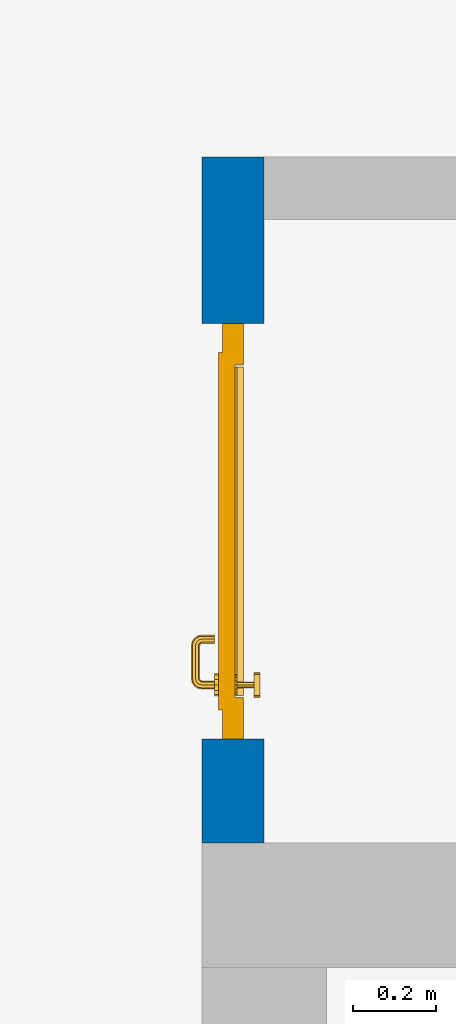
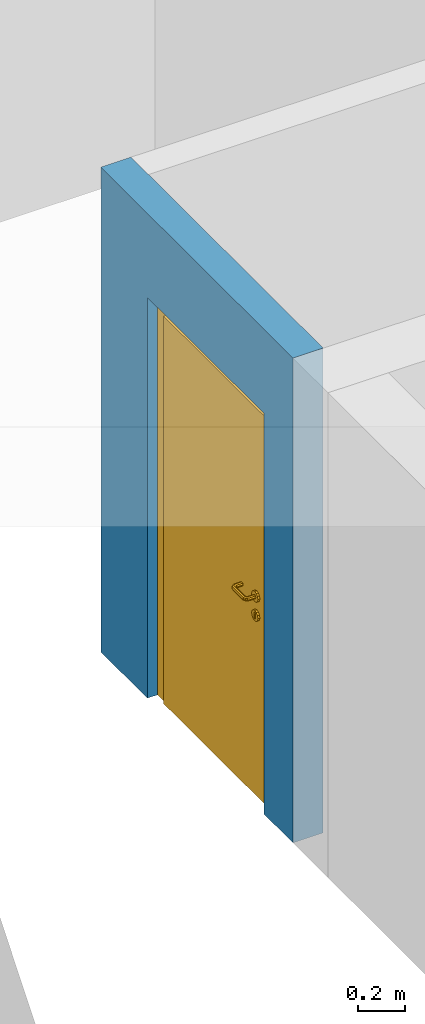
# One storey, part 15 of 48: 1 door, 1 wall, 1 opening.
"""IFC4 building model written with IfcOpenShell, lengths in metres."""

from ifc_helpers import new_model, entity, si_unit, converted_unit, derived_unit, direction, frame, origin_with_axes, place, context, subcontext, project, spatial, polygons, source, transform, mapped, material, type_object, element, fill, save


model = new_model("IFC4")

# Units and contexts
model_context = context("Model", 3, precision=1e-05, world=origin_with_axes(), true_north=direction((0.0, 1.0)))
body_context = subcontext(model_context, "Body", "Model", "MODEL_VIEW")
ifc_project = project(units=[si_unit("LENGTHUNIT", "METRE"), si_unit("AREAUNIT", "SQUARE_METRE"), si_unit("VOLUMEUNIT", "CUBIC_METRE"), converted_unit("PLANEANGLEUNIT", "DEGREE", entity("IfcPlaneAngleMeasure", 0.0174532925199), si_unit("PLANEANGLEUNIT", "RADIAN"), dimensions=[0, 0, 0, 0, 0, 0, 0]), converted_unit("TIMEUNIT", "Year", entity("IfcTimeMeasure", 31556926.0), si_unit("TIMEUNIT", "SECOND"), dimensions=[0, 0, 1, 0, 0, 0, 0]), si_unit("MASSUNIT", "GRAM", prefix="KILO"), si_unit("THERMODYNAMICTEMPERATUREUNIT", "DEGREE_CELSIUS"), si_unit("LUMINOUSINTENSITYUNIT", "LUMEN"), si_unit("ENERGYUNIT", "JOULE", prefix="MEGA"), derived_unit("THERMALCONDUCTANCEUNIT", [(si_unit("POWERUNIT", "WATT"), 1), (si_unit("LENGTHUNIT", "METRE"), -1), (si_unit("THERMODYNAMICTEMPERATUREUNIT", "KELVIN"), -1)]), derived_unit("SPECIFICHEATCAPACITYUNIT", [(si_unit("ENERGYUNIT", "JOULE"), 1), (si_unit("MASSUNIT", "GRAM", prefix="KILO"), -1), (si_unit("THERMODYNAMICTEMPERATUREUNIT", "KELVIN"), -1)]), derived_unit("MASSDENSITYUNIT", [(si_unit("MASSUNIT", "GRAM", prefix="KILO"), 1), (si_unit("VOLUMEUNIT", "CUBIC_METRE"), -1)])], contexts=[model_context])

# Site, building, storey
site_placement = place(None, origin_with_axes())
site = spatial("IfcSite", under=ifc_project, at=site_placement, CompositionType="ELEMENT")
building_placement = place(site_placement, origin_with_axes())
building = spatial("IfcBuilding", under=site, at=building_placement, CompositionType="ELEMENT")
storey_placement = place(building_placement, frame((0.0, 0.0, 3.4), z_axis=(0.0, 0.0, 1.0), x_axis=(1.0, 0.0, 0.0)))
storey = spatial("IfcBuildingStorey", under=building, at=storey_placement, Name="1. Geschoss", CompositionType="ELEMENT", Elevation=3.4)

# Wall, opening, door
ifc_material = material()
wall_type = type_object("IfcWallType", Name="150", PredefinedType="NOTDEFINED")
wall_placement = place(storey_placement, frame((-2.7421993804, 3.67118776896, 0.0), z_axis=(0.0, 0.0, 1.0), x_axis=(0.0, 1.0, 0.0)))
wall = element("IfcWall", 1, at=wall_placement, inside=storey, type_object=wall_type, material=ifc_material, Name="Wand-002", PredefinedType="NOTDEFINED", context=body_context, shape_type="Tessellation", body=[
    polygons([(0.55, -0.1, 2.1), (1.55, -0.1, 2.1), (1.55, -0.15, 2.1), (0.55, -0.15, 2.1), (0.55, 0.0, 2.1), (1.55, 0.0, 2.1), (1.55, -0.1, 0.0), (1.55, -0.15, 0.0), (1.95, -0.15, 2.54), (0.3, -0.15, 2.54), (0.3, -0.15, 0.0), (0.55, -0.15, 0.0), (1.95, -0.15, 0.0), (0.55, -0.1, 0.0), (0.55, 0.0, 0.0), (0.3, 0.0, 0.0), (0.3, 0.0, 2.54), (1.95, 0.0, 2.54), (1.95, 0.0, 0.0), (1.55, 0.0, 0.0)], [[[1, 2, 3, 4]], [[2, 1, 5, 6]], [[2, 7, 8, 3]], [[9, 10, 11, 12, 4, 3, 8, 13]], [[14, 1, 4, 12]], [[1, 14, 15, 5]], [[5, 15, 16, 17, 18, 19, 20, 6]], [[7, 2, 6, 20]], [[7, 20, 19, 13, 8]], [[9, 18, 17, 10]], [[17, 16, 11, 10]], [[15, 14, 12, 11, 16]], [[9, 13, 19, 18]]], closed=True),
])
opening_placement = place(wall_placement, frame((1.05, 0.0, 0.0), z_axis=(0.0, 0.0, 1.0), x_axis=(1.0, 0.0, 0.0)))
opening = element("IfcOpeningElement", 2, at=opening_placement, cuts=wall, context=body_context, identifier="Reference", shape_type="Tessellation", body=[
    polygons([(0.5, -0.1, 0.0), (0.5, -0.1, 2.1), (0.5, -0.151, 2.1), (0.5, -0.151, 0.0), (0.5, 0.001, 0.0), (0.5, 0.001, 2.1), (-0.5, -0.1, 2.1), (-0.5, -0.151, 2.1), (-0.5, 0.001, 2.1), (-0.5, -0.151, 0.0), (-0.5, -0.1, 0.0), (-0.5, 0.001, 0.0)], [[[1, 2, 3, 4]], [[2, 1, 5, 6]], [[7, 8, 3, 2, 6, 9]], [[8, 10, 4, 3]], [[1, 4, 10, 11, 12, 5]], [[6, 5, 12, 9]], [[7, 11, 10, 8]], [[11, 7, 9, 12]]], closed=True),
])
door_type = type_object("IfcDoorType", Name="Eingang 01 1-Fl 26", OperationType="SINGLE_SWING_RIGHT", PredefinedType="DOOR")
shared_shape = source(origin_with_axes(), body_context, "Body", "Tessellation", [
    polygons([(0.5, -0.05, 0.0), (0.5, -0.03, 0.0), (0.5, -0.03, 2.1), (0.5, -0.05, 2.1), (0.4, -0.05, 0.0), (0.4, -0.03, 0.0), (0.4, -0.03, 2.0), (0.1301, -0.03, 2.0), (0.0001, -0.03, 2.0), (-0.4, -0.03, 2.0), (-0.4, -0.03, 0.0), (-0.5, -0.03, 0.0), (-0.5, -0.03, 2.1), (-0.5, -0.05, 2.1), (-0.5, -0.05, 0.0), (-0.4, -0.05, 0.0), (-0.4, -0.05, 2.0), (0.0001, -0.05, 2.0), (0.1301, -0.05, 2.0), (0.4, -0.05, 2.0)], [[[1, 2, 3, 4]], [[5, 6, 2, 1]], [[2, 6, 7, 8, 9, 10, 11, 12, 13, 3]], [[4, 3, 13, 14]], [[1, 4, 14, 15, 16, 17, 18, 19, 20, 5]], [[20, 7, 6, 5]], [[19, 8, 7, 20]], [[18, 9, 8, 19]], [[17, 10, 9, 18]], [[16, 11, 10, 17]], [[15, 12, 11, 16]], [[14, 13, 12, 15]]], closed=True),
    polygons([(0.5, -0.03, 0.0), (0.5, 0.0, 0.0), (0.5, 0.0, 2.1), (0.5, -0.03, 2.1), (0.43, -0.03, 0.0), (0.43, 0.0, 0.0), (0.43, 0.0, 2.03), (0.1001, 0.0, 2.03), (0.0301, 0.0, 2.03), (-0.43, 0.0, 2.03), (-0.43, 0.0, 0.0), (-0.5, 0.0, 0.0), (-0.5, 0.0, 2.1), (-0.5, -0.03, 2.1), (-0.5, -0.03, 0.0), (-0.43, -0.03, 0.0), (-0.43, -0.03, 2.03), (0.0301, -0.03, 2.03), (0.1001, -0.03, 2.03), (0.43, -0.03, 2.03)], [[[1, 2, 3, 4]], [[5, 6, 2, 1]], [[2, 6, 7, 8, 9, 10, 11, 12, 13, 3]], [[4, 3, 13, 14]], [[1, 4, 14, 15, 16, 17, 18, 19, 20, 5]], [[20, 7, 6, 5]], [[19, 8, 7, 20]], [[18, 9, 8, 19]], [[17, 10, 9, 18]], [[16, 11, 10, 17]], [[15, 12, 11, 16]], [[14, 13, 12, 15]]], closed=True),
    polygons([(0.43, 0.01, 0.0), (-0.43, 0.01, 0.0), (-0.43, 0.01, 2.03), (0.43, 0.01, 2.03), (0.43, -0.03, 0.0), (-0.43, -0.03, 0.0), (-0.43, -0.03, 2.03), (0.43, -0.03, 2.03)], [[[1, 2, 3, 4]], [[2, 1, 5, 6]], [[3, 2, 6, 7]], [[4, 3, 7, 8]], [[1, 4, 8, 5]], [[6, 5, 8, 7]]], closed=True),
    polygons([(0.395, -0.05, 0.0), (0.395, -0.05, 0.05), (-0.395, -0.05, 0.05), (-0.395, -0.05, 0.0), (0.395, -0.03, 0.0), (0.395, -0.03, 0.07), (0.395, -0.035, 0.07), (-0.395, -0.035, 0.07), (-0.395, -0.03, 0.07), (-0.395, -0.03, 0.0)], [[[1, 2, 3, 4]], [[1, 5, 6, 7, 2]], [[2, 7, 8, 3]], [[4, 3, 8, 9, 10]], [[5, 1, 4, 10]], [[6, 5, 10, 9]], [[7, 6, 9, 8]]], closed=True),
    polygons([(-0.3835, 0.02, 1.0733826859), (-0.3835, 0.0199, 1.0733826859), (-0.37, 0.0199, 1.077), (-0.37, 0.02, 1.077), (-0.393382685902, 0.02, 1.0635), (-0.393382685902, 0.0199, 1.0635), (-0.3835, 0.0101, 1.0733826859), (-0.37, 0.0101, 1.077), (-0.3565, 0.0199, 1.0733826859), (-0.3565, 0.02, 1.0733826859), (-0.346617314098, 0.02, 1.0635), (-0.343, 0.02, 1.05), (-0.346617314098, 0.02, 1.0365), (-0.3565, 0.02, 1.0266173141), (-0.37, 0.02, 1.023), (-0.3835, 0.02, 1.0266173141), (-0.393382685902, 0.02, 1.0365), (-0.397, 0.02, 1.05), (-0.397, 0.0199, 1.05), (-0.393382685902, 0.0101, 1.0635), (-0.3835, 0.01, 1.0733826859), (-0.37, 0.01, 1.077), (-0.3565, 0.0101, 1.0733826859), (-0.346617314098, 0.0199, 1.0635), (-0.343, 0.0199, 1.05), (-0.346617314098, 0.0199, 1.0365), (-0.3565, 0.0199, 1.0266173141), (-0.37, 0.0199, 1.023), (-0.3835, 0.0199, 1.0266173141), (-0.393382685902, 0.0199, 1.0365), (-0.397, 0.0101, 1.05), (-0.393382685902, 0.01, 1.0635), (-0.397, 0.01, 1.05), (-0.393382685902, 0.01, 1.0365), (-0.3835, 0.01, 1.0266173141), (-0.37, 0.01, 1.023), (-0.3565, 0.01, 1.0266173141), (-0.346617314098, 0.01, 1.0365), (-0.343, 0.01, 1.05), (-0.346617314098, 0.01, 1.0635), (-0.3565, 0.01, 1.0733826859), (-0.346617314098, 0.0101, 1.0635), (-0.343, 0.0101, 1.05), (-0.346617314098, 0.0101, 1.0365), (-0.3565, 0.0101, 1.0266173141), (-0.37, 0.0101, 1.023), (-0.3835, 0.0101, 1.0266173141), (-0.393382685902, 0.0101, 1.0365)], [[[1, 2, 3, 4]], [[5, 6, 2, 1]], [[2, 7, 8, 3]], [[4, 3, 9, 10]], [[4, 10, 11, 12, 13, 14, 15, 16, 17, 18, 5, 1]], [[18, 19, 6, 5]], [[6, 20, 7, 2]], [[7, 21, 22, 8]], [[3, 8, 23, 9]], [[10, 9, 24, 11]], [[11, 24, 25, 12]], [[12, 25, 26, 13]], [[13, 26, 27, 14]], [[14, 27, 28, 15]], [[15, 28, 29, 16]], [[16, 29, 30, 17]], [[17, 30, 19, 18]], [[19, 31, 20, 6]], [[20, 32, 21, 7]], [[22, 21, 32, 33, 34, 35, 36, 37, 38, 39, 40, 41]], [[8, 22, 41, 23]], [[9, 23, 42, 24]], [[24, 42, 43, 25]], [[25, 43, 44, 26]], [[26, 44, 45, 27]], [[27, 45, 46, 28]], [[28, 46, 47, 29]], [[29, 47, 48, 30]], [[30, 48, 31, 19]], [[31, 33, 32, 20]], [[48, 34, 33, 31]], [[47, 35, 34, 48]], [[46, 36, 35, 47]], [[45, 37, 36, 46]], [[44, 38, 37, 45]], [[43, 39, 38, 44]], [[42, 40, 39, 43]], [[23, 41, 40, 42]]], closed=True),
    polygons([(-0.362532169224, 0.019, 0.959692280177), (-0.365, 0.019, 0.9544), (-0.365, 0.019, 0.952886751346), (-0.347569942042, 0.019, 0.96295), (-0.35705, 0.019, 0.972430057958), (-0.363279754556, 0.019, 0.961639806549), (-0.362532169224, 0.02, 0.959692280177), (-0.365, 0.02, 0.9544), (-0.365, 0.02, 0.952886751346), (-0.365, 0.02, 0.95), (-0.365, 0.02, 0.947113248654), (-0.365, 0.02, 0.941339745962), (-0.365, 0.02, 0.9375), (-0.365, 0.019, 0.9375), (-0.365, 0.019, 0.941339745962), (-0.365, 0.019, 0.947113248654), (-0.365, 0.019, 0.95), (-0.3441, 0.019, 0.95), (-0.347483339502, 0.019, 0.963), (-0.357, 0.019, 0.972516660498), (-0.364624817685, 0.019, 0.965143815798), (-0.37, 0.019, 0.9759), (-0.37, 0.019, 0.967425445323), (-0.364624817685, 0.02, 0.965143815798), (-0.363279754556, 0.02, 0.961639806549), (-0.35655, 0.02, 0.973296083362), (-0.346703916638, 0.02, 0.96345), (-0.3431, 0.02, 0.95), (-0.346703916638, 0.02, 0.93655), (-0.35655, 0.02, 0.926703916638), (-0.37, 0.02, 0.9231), (-0.37, 0.02, 0.9325), (-0.366464466094, 0.02, 0.933964466094), (-0.366464466094, 0.019, 0.933964466094), (-0.35705, 0.019, 0.927569942042), (-0.37, 0.019, 0.9325), (-0.37, 0.019, 0.9241), (-0.347569942042, 0.019, 0.93705), (-0.344, 0.019, 0.95), (-0.347483339502, 0.0189, 0.963), (-0.357, 0.0189, 0.972516660498), (-0.37, 0.019, 0.976), (-0.375375182315, 0.019, 0.965143815798), (-0.38295, 0.019, 0.972430057958), (-0.376720245444, 0.019, 0.961639806549), (-0.37, 0.02, 0.967425445323), (-0.37, 0.02, 0.9769), (-0.346617314098, 0.02, 0.9635), (-0.3565, 0.02, 0.973382685902), (-0.343, 0.02, 0.95), (-0.346617314098, 0.02, 0.9365), (-0.3565, 0.02, 0.926617314098), (-0.38345, 0.02, 0.926703916638), (-0.375, 0.02, 0.941339745962), (-0.375, 0.02, 0.9375), (-0.373535533906, 0.02, 0.933964466094), (-0.37, 0.02, 0.923), (-0.373535533906, 0.019, 0.933964466094), (-0.375, 0.019, 0.9375), (-0.375, 0.019, 0.941339745962), (-0.38295, 0.019, 0.927569942042), (-0.37, 0.019, 0.924), (-0.357, 0.019, 0.927483339502), (-0.347483339502, 0.019, 0.937), (-0.344, 0.0189, 0.95), (-0.347483339502, 0.0101, 0.963), (-0.357, 0.0101, 0.972516660498), (-0.37, 0.0189, 0.976), (-0.383, 0.019, 0.972516660498), (-0.375375182315, 0.02, 0.965143815798), (-0.377467830776, 0.019, 0.959692280177), (-0.392430057958, 0.019, 0.96295), (-0.375, 0.019, 0.952886751346), (-0.375, 0.019, 0.9544), (-0.377467830776, 0.02, 0.959692280177), (-0.376720245444, 0.02, 0.961639806549), (-0.38345, 0.02, 0.973296083362), (-0.37, 0.02, 0.977), (-0.346617314098, 0.0199, 0.9635), (-0.3565, 0.0199, 0.973382685902), (-0.343, 0.0199, 0.95), (-0.346617314098, 0.0199, 0.9365), (-0.3565, 0.0199, 0.926617314098), (-0.393296083362, 0.02, 0.93655), (-0.375, 0.02, 0.947113248654), (-0.375, 0.02, 0.9544), (-0.375, 0.019, 0.95), (-0.375, 0.019, 0.947113248654), (-0.375, 0.02, 0.95), (-0.375, 0.02, 0.952886751346), (-0.3835, 0.02, 0.926617314098), (-0.37, 0.0199, 0.923), (-0.392430057958, 0.019, 0.93705), (-0.383, 0.019, 0.927483339502), (-0.37, 0.0189, 0.924), (-0.357, 0.0189, 0.927483339502), (-0.347483339502, 0.0189, 0.937), (-0.344, 0.0101, 0.95), (-0.347483339502, 0.01, 0.963), (-0.357, 0.01, 0.972516660498), (-0.37, 0.0101, 0.976), (-0.383, 0.0189, 0.972516660498), (-0.392516660498, 0.019, 0.963), (-0.3959, 0.019, 0.95), (-0.393296083362, 0.02, 0.96345), (-0.3835, 0.02, 0.973382685902), (-0.37, 0.0199, 0.977), (-0.346617314098, 0.0101, 0.9635), (-0.3565, 0.0101, 0.973382685902), (-0.343, 0.0101, 0.95), (-0.346617314098, 0.0101, 0.9365), (-0.3565, 0.0101, 0.926617314098), (-0.393382685902, 0.02, 0.9365), (-0.3969, 0.02, 0.95), (-0.3835, 0.0199, 0.926617314098), (-0.37, 0.0101, 0.923), (-0.392516660498, 0.019, 0.937), (-0.383, 0.0189, 0.927483339502), (-0.37, 0.0101, 0.924), (-0.357, 0.0101, 0.927483339502), (-0.347483339502, 0.0101, 0.937), (-0.344, 0.01, 0.95), (-0.347396736961, 0.01, 0.96305), (-0.35695, 0.01, 0.972603263039), (-0.37, 0.01, 0.976), (-0.383, 0.0101, 0.972516660498), (-0.392516660498, 0.0189, 0.963), (-0.396, 0.019, 0.95), (-0.393382685902, 0.02, 0.9635), (-0.3835, 0.0199, 0.973382685902), (-0.37, 0.0101, 0.977), (-0.346617314098, 0.01, 0.9635), (-0.3565, 0.01, 0.973382685902), (-0.343, 0.01, 0.95), (-0.346617314098, 0.01, 0.9365), (-0.3565, 0.01, 0.926617314098), (-0.397, 0.02, 0.95), (-0.393382685902, 0.0199, 0.9365), (-0.3835, 0.0101, 0.926617314098), (-0.37, 0.01, 0.923), (-0.392516660498, 0.0189, 0.937), (-0.383, 0.0101, 0.927483339502), (-0.37, 0.01, 0.924), (-0.357, 0.01, 0.927483339502), (-0.347483339502, 0.01, 0.937), (-0.3439, 0.01, 0.95), (-0.346703916638, 0.01, 0.96345), (-0.35655, 0.01, 0.973296083362), (-0.37, 0.01, 0.9761), (-0.383, 0.01, 0.972516660498), (-0.392516660498, 0.0101, 0.963), (-0.396, 0.0189, 0.95), (-0.393382685902, 0.0199, 0.9635), (-0.3835, 0.0101, 0.973382685902), (-0.37, 0.01, 0.977), (-0.3431, 0.01, 0.95), (-0.346703916638, 0.01, 0.93655), (-0.35655, 0.01, 0.926703916638), (-0.397, 0.0199, 0.95), (-0.393382685902, 0.0101, 0.9365), (-0.3835, 0.01, 0.926617314098), (-0.37, 0.01, 0.9231), (-0.392516660498, 0.0101, 0.937), (-0.383, 0.01, 0.927483339502), (-0.37, 0.01, 0.9239), (-0.35695, 0.01, 0.927396736961), (-0.347396736961, 0.01, 0.93695), (-0.37, 0.01, 0.9769), (-0.38305, 0.01, 0.972603263039), (-0.392516660498, 0.01, 0.963), (-0.396, 0.0101, 0.95), (-0.393382685902, 0.0101, 0.9635), (-0.3835, 0.01, 0.973382685902), (-0.397, 0.0101, 0.95), (-0.393382685902, 0.01, 0.9365), (-0.38345, 0.01, 0.926703916638), (-0.392516660498, 0.01, 0.937), (-0.38305, 0.01, 0.927396736961), (-0.38345, 0.01, 0.973296083362), (-0.392603263039, 0.01, 0.96305), (-0.396, 0.01, 0.95), (-0.393382685902, 0.01, 0.9635), (-0.397, 0.01, 0.95), (-0.393296083362, 0.01, 0.93655), (-0.392603263039, 0.01, 0.93695), (-0.393296083362, 0.01, 0.96345), (-0.3961, 0.01, 0.95), (-0.3969, 0.01, 0.95)], [[[1, 2, 3, 4, 5, 6]], [[2, 1, 7, 8]], [[2, 8, 9, 10, 11, 12, 13, 14, 15, 16, 17, 3]], [[17, 18, 4, 3]], [[4, 19, 20, 5]], [[21, 6, 5, 22, 23]], [[1, 6, 21, 24, 25, 7]], [[7, 25, 26, 27, 9, 8]], [[9, 27, 28, 10]], [[10, 28, 29, 11]], [[11, 29, 30, 12]], [[31, 32, 33, 13, 12, 30]], [[14, 13, 33, 34]], [[35, 15, 14, 34, 36, 37]], [[15, 35, 38, 16]], [[16, 38, 18, 17]], [[18, 39, 19, 4]], [[19, 40, 41, 20]], [[5, 20, 42, 22]], [[43, 23, 22, 44, 45]], [[21, 23, 46, 24]], [[24, 46, 47, 26, 25]], [[48, 27, 26, 49]], [[50, 28, 27, 48]], [[51, 29, 28, 50]], [[52, 30, 29, 51]], [[53, 54, 55, 56, 32, 31]], [[34, 33, 32, 36]], [[57, 31, 30, 52]], [[37, 36, 58, 59, 60, 61]], [[37, 62, 63, 35]], [[35, 63, 64, 38]], [[38, 64, 39, 18]], [[39, 65, 40, 19]], [[40, 66, 67, 41]], [[20, 41, 68, 42]], [[22, 42, 69, 44]], [[23, 43, 70, 46]], [[71, 45, 44, 72, 73, 74]], [[43, 45, 71, 75, 76, 70]], [[70, 76, 77, 47, 46]], [[49, 26, 47, 78]], [[79, 48, 49, 80]], [[81, 50, 48, 79]], [[82, 51, 50, 81]], [[83, 52, 51, 82]], [[54, 53, 84, 85]], [[86, 74, 73, 87, 88, 60, 59, 55, 54, 85, 89, 90]], [[58, 56, 55, 59]], [[36, 32, 56, 58]], [[91, 53, 31, 57]], [[92, 57, 52, 83]], [[88, 93, 61, 60]], [[61, 94, 62, 37]], [[62, 95, 96, 63]], [[63, 96, 97, 64]], [[64, 97, 65, 39]], [[65, 98, 66, 40]], [[66, 99, 100, 67]], [[41, 67, 101, 68]], [[42, 68, 102, 69]], [[44, 69, 103, 72]], [[73, 72, 104, 87]], [[71, 74, 86, 75]], [[75, 86, 90, 105, 77, 76]], [[78, 47, 77, 106]], [[80, 49, 78, 107]], [[108, 79, 80, 109]], [[110, 81, 79, 108]], [[111, 82, 81, 110]], [[112, 83, 82, 111]], [[113, 84, 53, 91]], [[85, 84, 114, 89]], [[87, 104, 93, 88]], [[89, 114, 105, 90]], [[115, 91, 57, 92]], [[116, 92, 83, 112]], [[93, 117, 94, 61]], [[94, 118, 95, 62]], [[95, 119, 120, 96]], [[96, 120, 121, 97]], [[97, 121, 98, 65]], [[98, 122, 99, 66]], [[99, 123, 124, 100]], [[67, 100, 125, 101]], [[68, 101, 126, 102]], [[69, 102, 127, 103]], [[72, 103, 128, 104]], [[106, 77, 105, 129]], [[107, 78, 106, 130]], [[109, 80, 107, 131]], [[132, 108, 109, 133]], [[134, 110, 108, 132]], [[135, 111, 110, 134]], [[136, 112, 111, 135]], [[137, 114, 84, 113]], [[138, 113, 91, 115]], [[104, 128, 117, 93]], [[129, 105, 114, 137]], [[139, 115, 92, 116]], [[140, 116, 112, 136]], [[117, 141, 118, 94]], [[118, 142, 119, 95]], [[119, 143, 144, 120]], [[120, 144, 145, 121]], [[121, 145, 122, 98]], [[122, 146, 123, 99]], [[123, 147, 148, 124]], [[100, 124, 149, 125]], [[101, 125, 150, 126]], [[102, 126, 151, 127]], [[103, 127, 152, 128]], [[130, 106, 129, 153]], [[131, 107, 130, 154]], [[133, 109, 131, 155]], [[147, 132, 133, 148]], [[156, 134, 132, 147]], [[157, 135, 134, 156]], [[158, 136, 135, 157]], [[159, 137, 113, 138]], [[160, 138, 115, 139]], [[128, 152, 141, 117]], [[153, 129, 137, 159]], [[161, 139, 116, 140]], [[162, 140, 136, 158]], [[141, 163, 142, 118]], [[142, 164, 143, 119]], [[143, 165, 166, 144]], [[144, 166, 167, 145]], [[145, 167, 146, 122]], [[146, 156, 147, 123]], [[124, 148, 168, 149]], [[125, 149, 169, 150]], [[126, 150, 170, 151]], [[127, 151, 171, 152]], [[154, 130, 153, 172]], [[155, 131, 154, 173]], [[148, 133, 155, 168]], [[167, 157, 156, 146]], [[166, 158, 157, 167]], [[174, 159, 138, 160]], [[175, 160, 139, 161]], [[152, 171, 163, 141]], [[172, 153, 159, 174]], [[176, 161, 140, 162]], [[165, 162, 158, 166]], [[163, 177, 164, 142]], [[164, 178, 165, 143]], [[149, 168, 179, 169]], [[150, 169, 180, 170]], [[151, 170, 181, 171]], [[173, 154, 172, 182]], [[168, 155, 173, 179]], [[183, 174, 160, 175]], [[184, 175, 161, 176]], [[171, 181, 177, 163]], [[182, 172, 174, 183]], [[178, 176, 162, 165]], [[177, 185, 178, 164]], [[169, 179, 186, 180]], [[170, 180, 187, 181]], [[179, 173, 182, 186]], [[188, 183, 175, 184]], [[185, 184, 176, 178]], [[181, 187, 185, 177]], [[186, 182, 183, 188]], [[180, 186, 188, 187]], [[187, 188, 184, 185]]], closed=True),
    polygons([(-0.38, 0.02, 1.05), (-0.38, 0.0509849140336, 1.05), (-0.377071067812, 0.050696439392, 1.04292893219), (-0.377071067812, 0.02, 1.04292893219), (-0.377071067812, 0.02, 1.05707106781), (-0.377071067812, 0.050696439392, 1.05707106781), (-0.378277987014, 0.0596420579258, 1.05), (-0.375518993221, 0.0584992452783, 1.04292893219), (-0.37, 0.05, 1.04), (-0.37, 0.02, 1.04), (-0.37, 0.02, 1.06), (-0.37, 0.05, 1.06), (-0.375518993221, 0.0584992452783, 1.05707106781), (-0.372816199938, 0.0678161999379, 1.05), (-0.370704557509, 0.0657045575088, 1.04292893219), (-0.368858192988, 0.0557402514855, 1.04), (-0.362928932188, 0.049303560608, 1.04292893219), (-0.362928932188, 0.02, 1.04292893219), (-0.362928932188, 0.02, 1.05707106781), (-0.362928932188, 0.049303560608, 1.05707106781), (-0.368858192988, 0.0557402514855, 1.06), (-0.370704557509, 0.0657045575088, 1.05707106781), (-0.364642057926, 0.0732779870137, 1.05), (-0.363499245278, 0.0705189932208, 1.04292893219), (-0.365606601718, 0.0606066017178, 1.04), (-0.362197392755, 0.0529812576926, 1.04292893219), (-0.36, 0.0490150859664, 1.05), (-0.36, 0.02, 1.05), (-0.362197392755, 0.0529812576926, 1.05707106781), (-0.365606601718, 0.0606066017178, 1.06), (-0.363499245278, 0.0705189932208, 1.05707106781), (-0.355984914034, 0.075, 1.05), (-0.355696439392, 0.0720710678119, 1.04292893219), (-0.360740251485, 0.0638581929877, 1.04), (-0.360508645927, 0.0555086459268, 1.04292893219), (-0.359438398962, 0.0518384450452, 1.05), (-0.360508645927, 0.0555086459268, 1.05707106781), (-0.360740251485, 0.0638581929877, 1.06), (-0.355696439392, 0.0720710678119, 1.05707106781), (-0.274015085966, 0.075, 1.05), (-0.274303560608, 0.0720710678119, 1.04292893219), (-0.355, 0.065, 1.04), (-0.357981257693, 0.0571973927545, 1.04292893219), (-0.358397003498, 0.0533970034977, 1.05), (-0.357981257693, 0.0571973927545, 1.05707106781), (-0.355, 0.065, 1.06), (-0.274303560608, 0.0720710678119, 1.05707106781), (-0.265357942074, 0.0732779870137, 1.05), (-0.266500754722, 0.0705189932208, 1.04292893219), (-0.275, 0.065, 1.04), (-0.354303560608, 0.0579289321881, 1.04292893219), (-0.356838445045, 0.0544383989617, 1.05), (-0.354303560608, 0.0579289321881, 1.05707106781), (-0.275, 0.065, 1.06), (-0.266500754722, 0.0705189932208, 1.05707106781), (-0.257183800062, 0.0678161999379, 1.05), (-0.259295442491, 0.0657045575088, 1.04292893219), (-0.269259748515, 0.0638581929877, 1.04), (-0.275696439392, 0.0579289321881, 1.04292893219), (-0.354015085966, 0.055, 1.05), (-0.275696439392, 0.0579289321881, 1.05707106781), (-0.269259748515, 0.0638581929877, 1.06), (-0.259295442491, 0.0657045575088, 1.05707106781), (-0.251722012986, 0.0596420579258, 1.05), (-0.254481006779, 0.0584992452783, 1.04292893219), (-0.264393398282, 0.0606066017178, 1.04), (-0.272018742307, 0.0571973927545, 1.04292893219), (-0.275984914034, 0.055, 1.05), (-0.272018742307, 0.0571973927545, 1.05707106781), (-0.264393398282, 0.0606066017178, 1.06), (-0.254481006779, 0.0584992452783, 1.05707106781), (-0.25, 0.0509849140336, 1.05), (-0.252928932188, 0.050696439392, 1.04292893219), (-0.261141807012, 0.0557402514855, 1.04), (-0.269491354073, 0.0555086459268, 1.04292893219), (-0.273161554955, 0.0544383989617, 1.05), (-0.269491354073, 0.0555086459268, 1.05707106781), (-0.261141807012, 0.0557402514855, 1.06), (-0.252928932188, 0.050696439392, 1.05707106781), (-0.25, 0.02, 1.05), (-0.252928932188, 0.02, 1.04292893219), (-0.26, 0.05, 1.04), (-0.267802607245, 0.0529812576926, 1.04292893219), (-0.271602996502, 0.0533970034977, 1.05), (-0.267802607245, 0.0529812576926, 1.05707106781), (-0.26, 0.05, 1.06), (-0.252928932188, 0.02, 1.05707106781), (-0.26, 0.02, 1.06), (-0.267071067812, 0.02, 1.05707106781), (-0.27, 0.02, 1.05), (-0.267071067812, 0.02, 1.04292893219), (-0.26, 0.02, 1.04), (-0.267071067812, 0.049303560608, 1.04292893219), (-0.270561601038, 0.0518384450452, 1.05), (-0.267071067812, 0.049303560608, 1.05707106781), (-0.27, 0.0490150859664, 1.05)], [[[1, 2, 3, 4]], [[5, 6, 2, 1]], [[2, 7, 8, 3]], [[4, 3, 9, 10]], [[11, 12, 6, 5]], [[6, 13, 7, 2]], [[7, 14, 15, 8]], [[3, 8, 16, 9]], [[10, 9, 17, 18]], [[19, 20, 12, 11]], [[12, 21, 13, 6]], [[13, 22, 14, 7]], [[14, 23, 24, 15]], [[8, 15, 25, 16]], [[9, 16, 26, 17]], [[18, 17, 27, 28]], [[28, 27, 20, 19]], [[20, 29, 21, 12]], [[21, 30, 22, 13]], [[22, 31, 23, 14]], [[23, 32, 33, 24]], [[15, 24, 34, 25]], [[16, 25, 35, 26]], [[17, 26, 36, 27]], [[27, 36, 29, 20]], [[29, 37, 30, 21]], [[30, 38, 31, 22]], [[31, 39, 32, 23]], [[32, 40, 41, 33]], [[24, 33, 42, 34]], [[25, 34, 43, 35]], [[26, 35, 44, 36]], [[36, 44, 37, 29]], [[37, 45, 38, 30]], [[38, 46, 39, 31]], [[39, 47, 40, 32]], [[40, 48, 49, 41]], [[33, 41, 50, 42]], [[34, 42, 51, 43]], [[35, 43, 52, 44]], [[44, 52, 45, 37]], [[45, 53, 46, 38]], [[46, 54, 47, 39]], [[47, 55, 48, 40]], [[48, 56, 57, 49]], [[41, 49, 58, 50]], [[42, 50, 59, 51]], [[43, 51, 60, 52]], [[52, 60, 53, 45]], [[53, 61, 54, 46]], [[54, 62, 55, 47]], [[55, 63, 56, 48]], [[56, 64, 65, 57]], [[49, 57, 66, 58]], [[50, 58, 67, 59]], [[51, 59, 68, 60]], [[60, 68, 61, 53]], [[61, 69, 62, 54]], [[62, 70, 63, 55]], [[63, 71, 64, 56]], [[64, 72, 73, 65]], [[57, 65, 74, 66]], [[58, 66, 75, 67]], [[59, 67, 76, 68]], [[68, 76, 69, 61]], [[69, 77, 70, 62]], [[70, 78, 71, 63]], [[71, 79, 72, 64]], [[72, 80, 81, 73]], [[65, 73, 82, 74]], [[66, 74, 83, 75]], [[67, 75, 84, 76]], [[76, 84, 77, 69]], [[77, 85, 78, 70]], [[78, 86, 79, 71]], [[79, 87, 80, 72]], [[80, 87, 88, 89, 90, 91, 92, 81]], [[73, 81, 92, 82]], [[74, 82, 93, 83]], [[75, 83, 94, 84]], [[84, 94, 85, 77]], [[85, 95, 86, 78]], [[86, 88, 87, 79]], [[95, 89, 88, 86]], [[96, 90, 89, 95]], [[93, 91, 90, 96]], [[82, 92, 91, 93]], [[83, 93, 96, 94]], [[94, 96, 95, 85]]], closed=False),
    polygons([(-0.364696699141, -0.035, 1.04469669914), (-0.37, -0.035, 1.0425), (-0.375303300859, -0.035, 1.04469669914), (-0.3775, -0.035, 1.05), (-0.375303300859, -0.035, 1.05530330086), (-0.37, -0.035, 1.0575), (-0.364696699141, -0.035, 1.05530330086), (-0.3625, -0.035, 1.05), (-0.364696699141, -0.075, 1.04469669914), (-0.37, -0.075, 1.0425), (-0.375303300859, -0.075, 1.04469669914), (-0.3775, -0.075, 1.05), (-0.375303300859, -0.075, 1.05530330086), (-0.37, -0.075, 1.0575), (-0.364696699141, -0.075, 1.05530330086), (-0.3625, -0.075, 1.05)], [[[1, 2, 3, 4, 5, 6, 7, 8]], [[2, 1, 9, 10]], [[3, 2, 10, 11]], [[4, 3, 11, 12]], [[5, 4, 12, 13]], [[6, 5, 13, 14]], [[7, 6, 14, 15]], [[8, 7, 15, 16]], [[1, 8, 16, 9]], [[9, 16, 15, 14, 13, 12, 11, 10]]], closed=True),
    polygons([(-0.395, -0.03, 0.975), (-0.393096988313, -0.03, 0.965432914191), (-0.393096988313, -0.035, 0.965432914191), (-0.395, -0.035, 0.975), (-0.395, -0.03, 1.1), (-0.393096988313, -0.03, 1.10956708581), (-0.38767766953, -0.03, 1.11767766953), (-0.379567085809, -0.03, 1.12309698831), (-0.37, -0.03, 1.125), (-0.360432914191, -0.03, 1.12309698831), (-0.35232233047, -0.03, 1.11767766953), (-0.346903011687, -0.03, 1.10956708581), (-0.345, -0.03, 1.1), (-0.345, -0.03, 0.975), (-0.346903011687, -0.03, 0.965432914191), (-0.35232233047, -0.03, 0.95732233047), (-0.360432914191, -0.03, 0.951903011687), (-0.37, -0.03, 0.95), (-0.379567085809, -0.03, 0.951903011687), (-0.38767766953, -0.03, 0.95732233047), (-0.38767766953, -0.035, 0.95732233047), (-0.379567085809, -0.035, 0.951903011687), (-0.37, -0.035, 0.95), (-0.360432914191, -0.035, 0.951903011687), (-0.35232233047, -0.035, 0.95732233047), (-0.346903011687, -0.035, 0.965432914191), (-0.345, -0.035, 0.975), (-0.345, -0.035, 1.1), (-0.346903011687, -0.035, 1.10956708581), (-0.35232233047, -0.035, 1.11767766953), (-0.360432914191, -0.035, 1.12309698831), (-0.37, -0.035, 1.125), (-0.379567085809, -0.035, 1.12309698831), (-0.38767766953, -0.035, 1.11767766953), (-0.393096988313, -0.035, 1.10956708581), (-0.395, -0.035, 1.1)], [[[1, 2, 3, 4]], [[1, 5, 6, 7, 8, 9, 10, 11, 12, 13, 14, 15, 16, 17, 18, 19, 20, 2]], [[2, 20, 21, 3]], [[4, 3, 21, 22, 23, 24, 25, 26, 27, 28, 29, 30, 31, 32, 33, 34, 35, 36]], [[5, 1, 4, 36]], [[6, 5, 36, 35]], [[7, 6, 35, 34]], [[8, 7, 34, 33]], [[9, 8, 33, 32]], [[10, 9, 32, 31]], [[11, 10, 31, 30]], [[12, 11, 30, 29]], [[13, 12, 29, 28]], [[14, 13, 28, 27]], [[15, 14, 27, 26]], [[16, 15, 26, 25]], [[17, 16, 25, 24]], [[18, 17, 24, 23]], [[19, 18, 23, 22]], [[20, 19, 22, 21]]], closed=True),
    polygons([(-0.39, -0.075, 1.08), (-0.395, -0.075, 1.07866025404), (-0.395, -0.09, 1.07866025404), (-0.39, -0.09, 1.08), (-0.35, -0.075, 1.08), (-0.345, -0.075, 1.07866025404), (-0.341339745962, -0.075, 1.075), (-0.34, -0.075, 1.07), (-0.34, -0.075, 1.03), (-0.341339745962, -0.075, 1.025), (-0.345, -0.075, 1.02133974596), (-0.35, -0.075, 1.02), (-0.39, -0.075, 1.02), (-0.395, -0.075, 1.02133974596), (-0.398660254038, -0.075, 1.025), (-0.4, -0.075, 1.03), (-0.4, -0.075, 1.07), (-0.398660254038, -0.075, 1.075), (-0.398660254038, -0.09, 1.075), (-0.4, -0.09, 1.07), (-0.4, -0.09, 1.03), (-0.398660254038, -0.09, 1.025), (-0.395, -0.09, 1.02133974596), (-0.39, -0.09, 1.02), (-0.35, -0.09, 1.02), (-0.345, -0.09, 1.02133974596), (-0.341339745962, -0.09, 1.025), (-0.34, -0.09, 1.03), (-0.34, -0.09, 1.07), (-0.341339745962, -0.09, 1.075), (-0.345, -0.09, 1.07866025404), (-0.35, -0.09, 1.08)], [[[1, 2, 3, 4]], [[1, 5, 6, 7, 8, 9, 10, 11, 12, 13, 14, 15, 16, 17, 18, 2]], [[2, 18, 19, 3]], [[4, 3, 19, 20, 21, 22, 23, 24, 25, 26, 27, 28, 29, 30, 31, 32]], [[5, 1, 4, 32]], [[6, 5, 32, 31]], [[7, 6, 31, 30]], [[8, 7, 30, 29]], [[9, 8, 29, 28]], [[10, 9, 28, 27]], [[11, 10, 27, 26]], [[12, 11, 26, 25]], [[13, 12, 25, 24]], [[14, 13, 24, 23]], [[15, 14, 23, 22]], [[16, 15, 22, 21]], [[17, 16, 21, 20]], [[18, 17, 20, 19]]], closed=True),
])
door_placement = place(opening_placement, frame((-0.4, 0.0, 0.0), z_axis=(0.0, 0.0, 1.0), x_axis=(1.0, 0.0, 0.0)))
door = element("IfcDoor", 3, at=door_placement, inside=storey, type_object=door_type, OverallHeight=2.1, OverallWidth=1.0, PredefinedType="DOOR", context=body_context, shape_type="MappedRepresentation", body=[
    mapped(shared_shape, transform((0.4, -0.05, 0.0))),
])
fill(opening, door)

save(model, "model.ifc")
